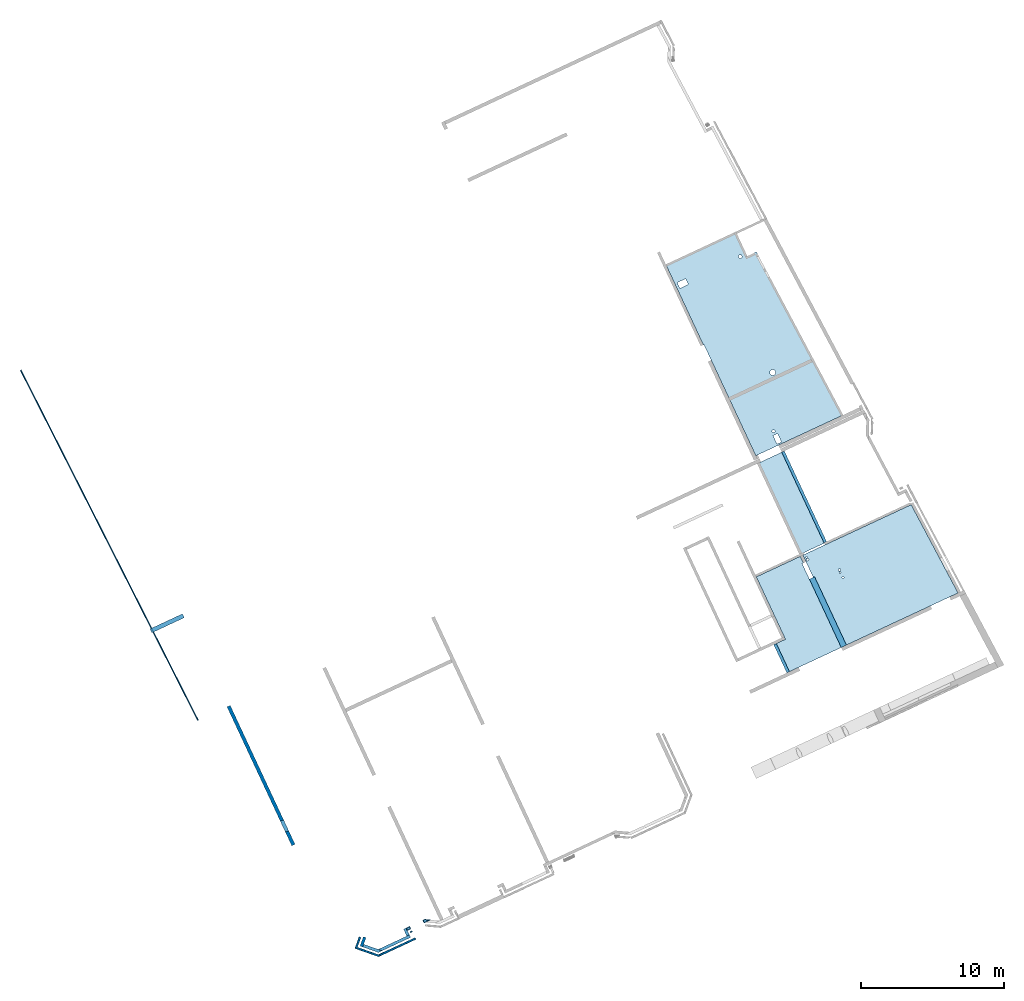
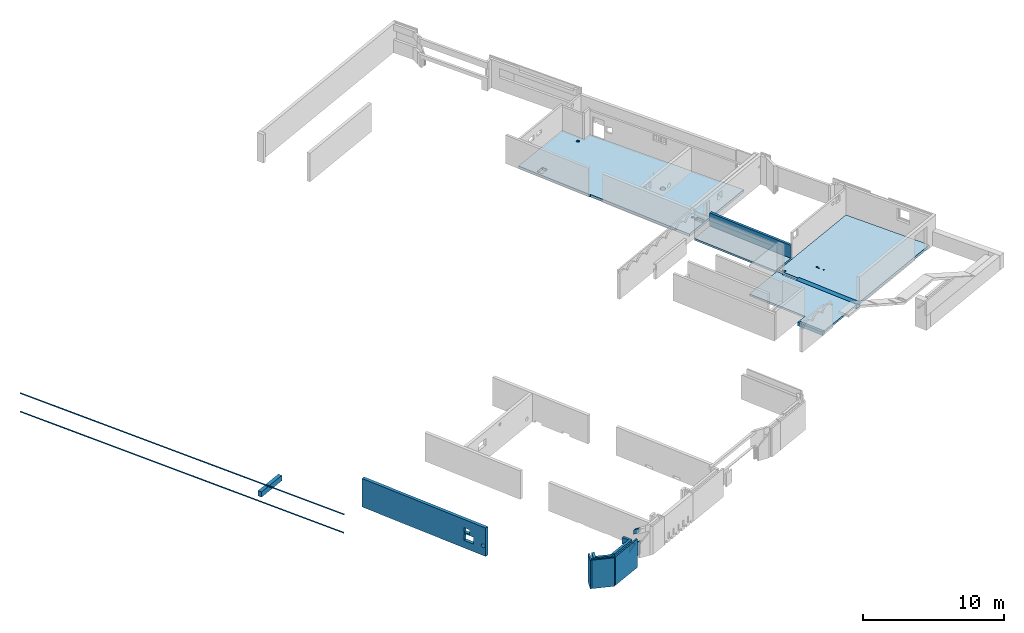
# One storey, part 1 of 13: 10 walls, 6 beams, 4 slabs, 18 openings.
"""IFC2X3 building model written with IfcOpenShell, lengths in metres."""

import ifcopenshell
import ifcopenshell.guid

model = None  # the IFC model being written
_history = None  # IfcOwnerHistory: only IFC2X3 demands one
_inside = {}  # id of a spatial element -> (the spatial element, [elements in it])
_under = {}  # id of a project, library or spatial element -> (it, [spatial elements below it])
_declared = {}  # id of a project -> (the project, [libraries it declares])
_typed = {}  # id of a type object -> (the type object, [elements of that type])
_made_of = {}  # id of a material, layer set ... -> (it, [elements and type objects made of it])


def new_model(schema):
    """Start an empty IFC model of exactly this schema.

    Asked for "IFC4X3", IfcOpenShell would pick the latest addendum, in which some entities
    have other attributes; the version numbers below select the first issue.
    IFC2X3 requires an IfcOwnerHistory on every rooted entity: one is made here for all.
    """
    global model, _history
    if schema == "IFC4X3":
        model = ifcopenshell.file(schema_version=(4, 3, 0, 0))
    else:
        model = ifcopenshell.file(schema=schema)
    _inside.clear()
    _under.clear()
    _declared.clear()
    _typed.clear()
    _made_of.clear()
    _history = None
    if model.schema == "IFC2X3":
        org = make("IfcOrganization", Name="unknown")
        user = make(
            "IfcPersonAndOrganization",
            ThePerson=make("IfcPerson", FamilyName="unknown"),
            TheOrganization=org,
        )
        app = make(
            "IfcApplication",
            ApplicationDeveloper=org,
            Version="unknown",
            ApplicationFullName="unknown",
            ApplicationIdentifier="unknown",
        )
        _history = make(
            "IfcOwnerHistory",
            OwningUser=user,
            OwningApplication=app,
            ChangeAction="ADDED",
            CreationDate=0,
        )
    return model


def make(cls, **values):
    """One entity of the class cls with the attributes given. An attribute that is None is left unset."""
    return model.create_entity(
        cls, **{name: value for name, value in values.items() if value is not None}
    )


def entity(cls, *values):
    """Any entity or typed value of the class cls, its attributes in the order of the schema. None: left unset."""
    e = model.create_entity(cls)
    for i, value in enumerate(values):
        if value is not None:
            e[i] = value
    return e


def rooted(cls, **values):
    """An entity with a GlobalId (a new one), such as an element, a storey or a relation."""
    return make(cls, GlobalId=ifcopenshell.guid.new(), OwnerHistory=_history, **values)


def si_unit(unit_type, name, prefix=None):
    """IfcSIUnit, for example si_unit("LENGTHUNIT", "METRE", prefix="MILLI")."""
    return make("IfcSIUnit", UnitType=unit_type, Prefix=prefix, Name=name)


def converted_unit(unit_type, name, factor, base, dimensions=None, offset=None):
    """IfcConversionBasedUnit, such as the inch: factor (a typed value) times the base unit."""
    return make(
        "IfcConversionBasedUnit"
        if offset is None
        else "IfcConversionBasedUnitWithOffset",
        ConversionOffset=offset,
        Dimensions=None
        if dimensions is None
        else entity("IfcDimensionalExponents", *dimensions),
        UnitType=unit_type,
        Name=name,
        ConversionFactor=make(
            "IfcMeasureWithUnit", ValueComponent=factor, UnitComponent=base
        ),
    )


def derived_unit(unit_type, elements):
    """IfcDerivedUnit: a product of units, each with its exponent."""
    return make(
        "IfcDerivedUnit",
        Elements=[
            make("IfcDerivedUnitElement", Unit=unit, Exponent=power)
            for unit, power in elements
        ],
        UnitType=unit_type,
    )


def assignment(units):
    """IfcUnitAssignment: the units of a project."""
    return None if units is None else make("IfcUnitAssignment", Units=units)


def point(xyz):
    """IfcCartesianPoint."""
    return None if xyz is None else make("IfcCartesianPoint", Coordinates=xyz)


def direction(xyz):
    """IfcDirection."""
    return None if xyz is None else make("IfcDirection", DirectionRatios=xyz)


def frame(location, z_axis=None, x_axis=None):
    """IfcAxis2Placement3D, a coordinate frame: its origin and axes. An axis left out is left unset."""
    return make(
        "IfcAxis2Placement3D",
        Location=point(location),
        Axis=direction(z_axis),
        RefDirection=direction(x_axis),
    )


def frame_2d(location, x_axis=None):
    """IfcAxis2Placement2D, a coordinate frame in the plane: its origin and x axis."""
    return make(
        "IfcAxis2Placement2D", Location=point(location), RefDirection=direction(x_axis)
    )


def origin():
    """The frame at (0, 0, 0) with its axes left unset."""
    return frame((0.0, 0.0, 0.0))


def origin_2d_with_axis():
    """The frame at (0, 0) in the plane with the x axis (1, 0) written out."""
    return frame_2d((0.0, 0.0), x_axis=(1.0, 0.0))


def place(relative_to, where):
    """IfcLocalPlacement: puts the frame where relative to a parent placement (None: the world)."""
    return make(
        "IfcLocalPlacement", PlacementRelTo=relative_to, RelativePlacement=where
    )


def context(
    kind, dimensions, precision=None, world=None, true_north=None, identifier=None
):
    """IfcGeometricRepresentationContext, for example the 3D "Model" context."""
    return make(
        "IfcGeometricRepresentationContext",
        ContextIdentifier=identifier,
        ContextType=kind,
        CoordinateSpaceDimension=dimensions,
        Precision=precision,
        WorldCoordinateSystem=world,
        TrueNorth=true_north,
    )


def subcontext(parent, identifier, kind, view, scale=None):
    """IfcGeometricRepresentationSubContext, for example "Body" below "Model"."""
    return make(
        "IfcGeometricRepresentationSubContext",
        ContextIdentifier=identifier,
        ContextType=kind,
        ParentContext=parent,
        TargetScale=scale,
        TargetView=view,
    )


def project(units=None, contexts=None):
    """IfcProject with its units and contexts."""
    return rooted(
        "IfcProject",
        Name="project",
        RepresentationContexts=contexts,
        UnitsInContext=assignment(units),
    )


def spatial(cls, under=None, at=None, **own):
    """A site, building, storey or space (cls), placed at a placement, below another one or the project."""
    s = rooted(cls, ObjectPlacement=at, **own)
    if under is not None:
        _under.setdefault(under.id(), (under, []))[1].append(s)
    return s


def polyline(points):
    """IfcPolyline through the points."""
    return make("IfcPolyline", Points=[point(p) for p in points])


def profile(cls, at=None, kind="AREA", **sizes):
    """A parametric profile (cls). Its sizes go by their IFC names, for example OverallWidth=200.0."""
    return make(cls, ProfileType=kind, Position=at, **sizes)


def rectangle(**sizes):
    """IfcRectangleProfileDef."""
    return profile("IfcRectangleProfileDef", **sizes)


def circle(**sizes):
    """IfcCircleProfileDef."""
    return profile("IfcCircleProfileDef", **sizes)


def hollow_circle(**sizes):
    """IfcCircleHollowProfileDef."""
    return profile("IfcCircleHollowProfileDef", **sizes)


def outline(outer, holes=None, kind="AREA"):
    """IfcArbitraryClosedProfileDef: a profile drawn as a closed curve; with holes, ...WithVoids."""
    if holes is None:
        return make("IfcArbitraryClosedProfileDef", ProfileType=kind, OuterCurve=outer)
    return make(
        "IfcArbitraryProfileDefWithVoids",
        ProfileType=kind,
        OuterCurve=outer,
        InnerCurves=holes,
    )


def extrude(swept, where, along, depth):
    """IfcExtrudedAreaSolid: the profile swept, set in the frame where, extruded along a direction by depth."""
    return make(
        "IfcExtrudedAreaSolid",
        SweptArea=swept,
        Position=where,
        ExtrudedDirection=direction(along),
        Depth=depth,
    )


def clip(a, b, op="DIFFERENCE"):
    """IfcBooleanClippingResult: the solid a cut by the half space b."""
    return make(
        "IfcBooleanClippingResult", Operator=op, FirstOperand=a, SecondOperand=b
    )


def halfspace(plane, agree):
    """IfcHalfSpaceSolid: all space on one side of the plane z = 0 of the frame plane."""
    return make(
        "IfcHalfSpaceSolid",
        BaseSurface=make("IfcPlane", Position=plane),
        AgreementFlag=agree,
    )


def shape(context_of_items, identifier, shape_type, items):
    """IfcShapeRepresentation: the items that make up one representation, for example the "Body"."""
    return make(
        "IfcShapeRepresentation",
        ContextOfItems=context_of_items,
        RepresentationIdentifier=identifier,
        RepresentationType=shape_type,
        Items=items,
    )


def material(Name=None, Category=None):
    """IfcMaterial."""
    return make("IfcMaterial", Name=Name, Category=Category)


def layer(
    of_material, thickness, ventilated=None, Name=None, Category=None, Priority=None
):
    """IfcMaterialLayer: one layer of a wall or slab, of a material (None: an air gap)."""
    return make(
        "IfcMaterialLayer",
        Material=of_material,
        LayerThickness=thickness,
        IsVentilated=ventilated,
        Name=Name,
        Category=Category,
        Priority=Priority,
    )


def layer_set(layers, Name=None):
    """IfcMaterialLayerSet."""
    return make("IfcMaterialLayerSet", MaterialLayers=layers, LayerSetName=Name)


def layer_usage(for_layer_set, set_direction, sense, offset, extent=None):
    """IfcMaterialLayerSetUsage: how a layer set lies in its element."""
    return make(
        "IfcMaterialLayerSetUsage",
        ForLayerSet=for_layer_set,
        LayerSetDirection=set_direction,
        DirectionSense=sense,
        OffsetFromReferenceLine=offset,
        ReferenceExtent=extent,
    )


def made_of(thing, what):
    """Note that an element or type object is made of a material, layer set ...; save() writes the relation."""
    if what is not None:
        _made_of.setdefault(what.id(), (what, []))[1].append(thing)
    return thing


def type_object(cls, material=None, **own):
    """A type object (cls), such as IfcWallType, which elements share."""
    return made_of(rooted(cls, **own), material)


def element(
    cls,
    number,
    at=None,
    inside=None,
    cuts=None,
    type_object=None,
    material=None,
    context=None,
    identifier="Body",
    shape_type=None,
    held_by="IfcProductDefinitionShape",
    body=None,
    shapes=None,
    **own,
):
    """One element of the class cls, such as IfcWall. Its Tag is "e" and its number.

    at: its placement. inside: the storey or other place that contains it. cuts: it is an
    opening in that element (IfcRelVoidsElement). A single representation is given by context,
    identifier, shape_type and body (its items); several are given by shapes. held_by: the class
    of the entity that holds the representations. save() writes the other relations.
    """
    e = rooted(cls, Tag="e%d" % number, ObjectPlacement=at, **own)
    if body is not None:
        shapes = [shape(context, identifier, shape_type, body)]
    if shapes is not None:
        e.Representation = make(held_by, Representations=shapes)
    if inside is not None:
        _inside.setdefault(inside.id(), (inside, []))[1].append(e)
    if cuts is not None:
        rooted(
            "IfcRelVoidsElement", RelatingBuildingElement=cuts, RelatedOpeningElement=e
        )
    if type_object is not None:
        _typed.setdefault(type_object.id(), (type_object, []))[1].append(e)
    return made_of(e, material)


def aggregate(whole, parts):
    """IfcRelAggregates: a whole, such as a stair, and the parts it consists of."""
    return rooted("IfcRelAggregates", RelatingObject=whole, RelatedObjects=parts)


def save(model, path):
    """Write the relations noted so far, then the file.

    IfcRelAggregates (storeys below a building ...), IfcRelContainedInSpatialStructure (elements
    in a storey), IfcRelDefinesByType, IfcRelAssociatesMaterial and IfcRelDeclares: one each for
    every whole, place, type object, material and project.
    """
    for whole, parts in _under.values():
        aggregate(whole, parts)
    for where, things in _inside.values():
        rooted(
            "IfcRelContainedInSpatialStructure",
            RelatedElements=things,
            RelatingStructure=where,
        )
    for kind, things in _typed.values():
        rooted("IfcRelDefinesByType", RelatedObjects=things, RelatingType=kind)
    for what, things in _made_of.values():
        rooted("IfcRelAssociatesMaterial", RelatedObjects=things, RelatingMaterial=what)
    for by, libraries in _declared.values():
        rooted("IfcRelDeclares", RelatingContext=by, RelatedDefinitions=libraries)
    model.write(path)


model = new_model("IFC2X3")

# Units and contexts
model_context = context("Model", 3, precision=1e-05, world=origin(), true_north=direction((6.12303176911189e-17, 1.0)))
body_context = subcontext(model_context, "Body", "Model", "MODEL_VIEW")
ifc_project = project(units=[si_unit("LENGTHUNIT", "METRE"), si_unit("AREAUNIT", "SQUARE_METRE"), si_unit("VOLUMEUNIT", "CUBIC_METRE"), converted_unit("PLANEANGLEUNIT", "DEGREE", entity("IfcRatioMeasure", 0.0174532925199433), si_unit("PLANEANGLEUNIT", "RADIAN"), dimensions=[0, 0, 0, 0, 0, 0, 0]), si_unit("MASSUNIT", "GRAM", prefix="KILO"), derived_unit("MASSDENSITYUNIT", [(si_unit("MASSUNIT", "GRAM", prefix="KILO"), 1), (si_unit("LENGTHUNIT", "METRE"), -3)]), si_unit("TIMEUNIT", "SECOND"), si_unit("FREQUENCYUNIT", "HERTZ"), si_unit("THERMODYNAMICTEMPERATUREUNIT", "DEGREE_CELSIUS"), derived_unit("THERMALTRANSMITTANCEUNIT", [(si_unit("MASSUNIT", "GRAM", prefix="KILO"), 1), (si_unit("THERMODYNAMICTEMPERATUREUNIT", "KELVIN"), -1), (si_unit("TIMEUNIT", "SECOND"), -3)]), derived_unit("VOLUMETRICFLOWRATEUNIT", [(si_unit("LENGTHUNIT", "METRE"), 3), (si_unit("TIMEUNIT", "SECOND"), -1)]), si_unit("ELECTRICCURRENTUNIT", "AMPERE"), si_unit("ELECTRICVOLTAGEUNIT", "VOLT"), si_unit("POWERUNIT", "WATT"), si_unit("FORCEUNIT", "NEWTON", prefix="KILO"), si_unit("ILLUMINANCEUNIT", "LUX"), si_unit("LUMINOUSFLUXUNIT", "LUMEN"), si_unit("LUMINOUSINTENSITYUNIT", "CANDELA"), derived_unit("USERDEFINED", [(si_unit("MASSUNIT", "GRAM", prefix="KILO"), -1), (si_unit("LENGTHUNIT", "METRE"), -2), (si_unit("TIMEUNIT", "SECOND"), 3), (si_unit("LUMINOUSFLUXUNIT", "LUMEN"), 1)]), derived_unit("LINEARVELOCITYUNIT", [(si_unit("LENGTHUNIT", "METRE"), 1), (si_unit("TIMEUNIT", "SECOND"), -1)]), si_unit("PRESSUREUNIT", "PASCAL"), derived_unit("USERDEFINED", [(si_unit("LENGTHUNIT", "METRE"), -2), (si_unit("MASSUNIT", "GRAM", prefix="KILO"), 1), (si_unit("TIMEUNIT", "SECOND"), -2)])], contexts=[model_context])

# Site, building, storey
site_placement = place(None, frame((5.36960000000003, 43.3158000000006, 0.0), z_axis=(0.0, 0.0, 1.0), x_axis=(-0.422618261740703, 0.906307787036648, 0.0)))
site = spatial("IfcSite", under=ifc_project, at=site_placement, CompositionType="ELEMENT")
building_placement = place(site_placement, origin())
building = spatial("IfcBuilding", under=site, at=building_placement, CompositionType="ELEMENT")
storey_placement = place(building_placement, frame((0.0, 0.0, 2.56)))
storey = spatial("IfcBuildingStorey", under=building, at=storey_placement, CompositionType="ELEMENT", Elevation=2.56)

# Beams
ifc_material_1 = material(Name="Acier structurel - S235")
beam_type_1 = type_object("IfcBeamType", Name="CHM_10_:01_Rond Creux 101.6x5", PredefinedType="BEAM", material=ifc_material_1)
beam_1_placement = place(storey_placement, frame((47.7991430909381, 53.683780797535, 0.690825037722072), z_axis=(-1.66798992952093e-06, -5.39854392808255e-08, 1.0), x_axis=(-0.999476646181147, -0.0323486280342907, -1.6688633355184e-06)))
element("IfcBeam", 1, at=beam_1_placement, inside=storey, type_object=beam_type_1, material=ifc_material_1, Name="10_:01_Rond Creux 101.6x5", ObjectType="CHM_10_:01_Rond Creux 101.6x5", context=body_context, shape_type="SweptSolid", body=[
    extrude(hollow_circle(Radius=0.0508000000000008, WallThickness=0.0050000000000008, at=origin_2d_with_axis()), frame((-0.00220000000009409, 0.0, -0.0508000000000042), z_axis=(1.0, 0.0, 0.0), x_axis=(0.0, 1.0, 0.0)), (0.0, 0.0, 1.0), 27.4882),
])
beam_2_placement = place(storey_placement, frame((47.8006608482374, 53.6837846191832, -0.909199999999946), z_axis=(0.0, 0.0, 1.0), x_axis=(-0.999476646182541, -0.0323486280342909, 0.0)))
element("IfcBeam", 2, at=beam_2_placement, inside=storey, type_object=beam_type_1, material=ifc_material_1, Name="10_:01_Rond Creux 101.6x5", ObjectType="CHM_10_:01_Rond Creux 101.6x5", context=body_context, shape_type="SweptSolid", body=[
    extrude(hollow_circle(Radius=0.0508000000000008, WallThickness=0.0050000000000008, at=frame_2d((0.0, -2.70716782324598e-16), x_axis=(1.0, 0.0))), frame((-0.000687526736847471, 0.0, -0.0508000000000039), z_axis=(1.0, 0.0, 0.0), x_axis=(0.0, 1.0, 0.0)), (0.0, 0.0, 1.0), 27.4653),
])
ifc_material_2 = material(Name="C25/30 XC1")
beam_type_2 = type_object("IfcBeamType", Name="SP_20_:15_Poutre 20x128h", PredefinedType="BEAM")
beam_3_placement = place(storey_placement, frame((13.0006608482374, 7.73252584902486, -0.159999999999997)))
element("IfcBeam", 3, at=beam_3_placement, inside=storey, type_object=beam_type_2, material=ifc_material_2, Name="SP_20_:15_Poutre 20x128h", ObjectType="SP_20_:15_Poutre 20x128h", context=body_context, shape_type="SweptSolid", body=[
    extrude(rectangle(XDim=1.12, YDim=0.2, at=frame_2d((5.55111512312578e-16, 5.84740589282262e-14), x_axis=(1.0, 0.0))), frame((0.0799999999999998, 0.0, 0.719999999999998), z_axis=(1.0, 0.0, 0.0), x_axis=(0.0, 0.0, -1.0)), (0.0, 0.0, 1.0), 6.99500115363823),
])
ifc_material_3 = material(Name="C40/50 XC1")
beam_type_3 = type_object("IfcBeamType", Name="SP_20_:31_Poutre 40x40h", PredefinedType="BEAM")
beam_4_placement = place(storey_placement, frame((5.8006608482374, 9.63252584903126, 0.0)))
element("IfcBeam", 4, at=beam_4_placement, inside=storey, type_object=beam_type_3, material=ifc_material_3, Name="SP_20_:31_Poutre 40x40h", ObjectType="SP_20_:31_Poutre 40x40h", context=body_context, shape_type="SweptSolid", body=[
    extrude(rectangle(XDim=0.4, YDim=0.4, at=frame_2d((0.0, 4.81659157003378e-12), x_axis=(1.0, 0.0))), frame((0.12499999999982, 0.0, -0.200000000000002), z_axis=(1.0, 0.0, 0.0), x_axis=(0.0, 0.0, -1.0)), (0.0, 0.0, 1.0), 5.27500050894108),
])
beam_type_4 = type_object("IfcBeamType", Name="SP_20_:05_Poutre 20 x 31ht", PredefinedType="BEAM")
beam_5_placement = place(storey_placement, frame((8.20066084823747, 13.9325037603591, 0.0), z_axis=(0.0, 0.0, 1.0), x_axis=(-1.0, 0.0, 0.0)))
element("IfcBeam", 5, at=beam_5_placement, inside=storey, type_object=beam_type_4, material=ifc_material_2, Name="SP_20_:05_Poutre 20 x 31ht", ObjectType="SP_20_:05_Poutre 20 x 31ht", context=body_context, shape_type="SweptSolid", body=[
    extrude(rectangle(XDim=0.31, YDim=0.199999999999998, at=frame_2d((0.0, 2.38212227721135e-14), x_axis=(1.0, 0.0))), frame((0.100001063957546, 0.0, -0.155000000000002), z_axis=(1.0, 0.0, 0.0), x_axis=(0.0, 0.0, -1.0)), (0.0, 0.0, 1.0), 2.175),
])
ifc_material_4 = material(Name="C30/37 XS1")
beam_type_5 = type_object("IfcBeamType", Name="SP_20_:26_Poutre 30x46h", PredefinedType="BEAM")
beam_6_placement = place(storey_placement, frame((27.4006192535275, 53.1373971249629, 0.0), z_axis=(0.0, 0.0, 1.0), x_axis=(0.0, -1.0, 0.0)))
element("IfcBeam", 6, at=beam_6_placement, inside=storey, type_object=beam_type_5, material=ifc_material_4, Name="SP_20_:26_Poutre 30x46h", ObjectType="SP_20_:26_Poutre 30x46h", context=body_context, shape_type="SweptSolid", body=[
    extrude(rectangle(XDim=0.46, YDim=0.300000000000005, at=frame_2d((2.63677968348475e-16, 2.16493489801906e-15), x_axis=(1.0, 0.0))), frame((0.0, 0.0, -0.230000000000001), z_axis=(1.0, 0.0, 0.0), x_axis=(0.0, 0.0, -1.0)), (0.0, 0.0, 1.0), 2.50770000000001),
])

# Slab, openings
ifc_layer_1 = layer(ifc_material_2, 0.22)
ifc_layer_set_1 = layer_set([ifc_layer_1], Name="Sol:SP_40_06_Dalle BET22")
ifc_layer_usage_1 = layer_usage(ifc_layer_set_1, "AXIS3", "POSITIVE", 0.0)
slab_type_1 = type_object("IfcSlabType", Name="Sol:SP_40_06_Dalle BET22", PredefinedType="FLOOR", material=ifc_layer_set_1)
slab_1_placement = place(storey_placement, frame((20.6156620018758, 2.83449320546499, -0.160000000000001)))
slab_1 = element("IfcSlab", 7, at=slab_1_placement, inside=storey, type_object=slab_type_1, material=ifc_layer_usage_1, Name="Sol:SP_40_06_Dalle BET22", ObjectType="Sol:SP_40_06_Dalle BET22", PredefinedType="FLOOR", context=body_context, shape_type="SweptSolid", body=[
    extrude(outline(polyline([(-7.40276950259555, -2.01885991005166), (-5.51222725007326, -2.01885991005165), (-5.51222725007325, -2.72496830778786), (7.40276950259559, -3.39901632177972), (7.40276950259553, 3.34901632177979), (-1.18222934376573, 3.34901632177972), (-1.18222934376573, 3.39901632177979), (-7.4027695025956, 3.39901632177972), (-7.40276950259555, -2.01885991005166)])), frame((7.40276950259559, 3.39901632177972, 0.220000000000001), z_axis=(0.0, 0.0, -1.0), x_axis=(-1.0, 0.0, 0.0)), (0.0, 0.0, 1.0), 0.22),
])
opening_1_placement = place(slab_1_placement, origin())
element("IfcOpeningElement", 8, at=opening_1_placement, cuts=slab_1, ObjectType="Opening", context=body_context, shape_type="SweptSolid", body=[
    extrude(rectangle(XDim=0.35, YDim=0.649999999999999, at=origin_2d_with_axis()), frame((0.439440943100025, 4.88117728273939, -0.0800000000000013), z_axis=(0.0, 0.0, 1.0), x_axis=(0.0, 1.0, 0.0)), (0.0, 0.0, 1.0), 0.5),
])
opening_2_placement = place(slab_1_placement, origin())
element("IfcOpeningElement", 9, at=opening_2_placement, cuts=slab_1, ObjectType="Opening", context=body_context, shape_type="SweptSolid", body=[
    extrude(circle(Radius=0.200000000000012, at=origin_2d_with_axis()), frame((4.78470411792951, 3.21118867164955, -0.0800000000000013)), (0.0, 0.0, 1.0), 0.5),
])
opening_3_placement = place(slab_1_placement, origin())
element("IfcOpeningElement", 10, at=opening_3_placement, cuts=slab_1, ObjectType="Opening", context=body_context, shape_type="SweptSolid", body=[
    extrude(circle(Radius=0.0999999999999979, at=origin_2d_with_axis()), frame((1.02944094309986, 4.89818423578489, -0.0800000000000013)), (0.0, 0.0, 1.0), 0.5),
])
opening_4_placement = place(slab_1_placement, origin())
element("IfcOpeningElement", 11, at=opening_4_placement, cuts=slab_1, ObjectType="Opening", context=body_context, shape_type="SweptSolid", body=[
    extrude(circle(Radius=0.124999999999998, at=origin_2d_with_axis()), frame((13.1000212835624, 1.84812233774764, -0.0800000000000013)), (0.0, 0.0, 1.0), 0.5),
])
opening_5_placement = place(slab_1_placement, origin())
element("IfcOpeningElement", 12, at=opening_5_placement, cuts=slab_1, ObjectType="Opening", context=body_context, shape_type="SweptSolid", body=[
    extrude(rectangle(XDim=0.444999999999999, YDim=0.649999999999999, at=origin_2d_with_axis()), frame((13.0869409430997, 6.28525567428294, -0.0800000000000013), z_axis=(0.0, 0.0, 1.0), x_axis=(-1.0, 0.0, 0.0)), (0.0, 0.0, 1.0), 0.5),
])

ifc_layer_usage_2 = layer_usage(ifc_layer_set_1, "AXIS3", "POSITIVE", 0.0)
slab_2_placement = place(storey_placement, frame((5.92566084823725, 0.806025013909039, -0.22)))
slab_2 = element("IfcSlab", 13, at=slab_2_placement, inside=storey, type_object=slab_type_1, material=ifc_layer_usage_2, Name="Sol:SP_40_06_Dalle BET22", ObjectType="Sol:SP_40_06_Dalle BET22", PredefinedType="FLOOR", context=body_context, shape_type="SweptSolid", body=[
    extrude(outline(polyline([(3.4975000000001, 4.3632504175576), (-3.49750000000017, 4.36325041755753), (-3.4975000000001, -3.99817328560245), (3.49750000000018, -4.36325041755754), (3.4975000000001, 4.3632504175576)])), frame((3.49750000000018, 4.36325041755754, 0.22), z_axis=(0.0, 0.0, -1.0), x_axis=(-1.0, 0.0, 0.0)), (0.0, 0.0, 1.0), 0.22),
])
opening_6_placement = place(storey_placement, frame((5.92566084823725, 0.806025013909039, -0.22)))
element("IfcOpeningElement", 14, at=opening_6_placement, cuts=slab_2, ObjectType="Opening", context=body_context, shape_type="SweptSolid", body=[
    extrude(circle(Radius=0.08, at=frame_2d((-3.06776047783623, 4.19505917639782), x_axis=(1.0, 0.0))), frame((3.49750000000018, 4.36325041755754, 0.22), z_axis=(0.0, 0.0, -1.0), x_axis=(-1.0, 0.0, 0.0)), (0.0, 0.0, 1.0), 0.22),
])
opening_7_placement = place(storey_placement, frame((5.92566084823725, 0.806025013909039, -0.22)))
element("IfcOpeningElement", 15, at=opening_7_placement, cuts=slab_2, ObjectType="Opening", context=body_context, shape_type="SweptSolid", body=[
    extrude(circle(Radius=0.05, at=frame_2d((-3.25420201195466, 4.19326188063582), x_axis=(1.0, 0.0))), frame((3.49750000000018, 4.36325041755754, 0.22), z_axis=(0.0, 0.0, -1.0), x_axis=(-1.0, 0.0, 0.0)), (0.0, 0.0, 1.0), 0.22),
])
opening_8_placement = place(storey_placement, frame((5.92566084823725, 0.806025013909039, -0.22)))
element("IfcOpeningElement", 16, at=opening_8_placement, cuts=slab_2, ObjectType="Opening", context=body_context, shape_type="SweptSolid", body=[
    extrude(circle(Radius=0.08, at=frame_2d((-1.46885343441837, 2.48471308064029), x_axis=(1.0, 0.0))), frame((3.49750000000018, 4.36325041755754, 0.22), z_axis=(0.0, 0.0, -1.0), x_axis=(-1.0, 0.0, 0.0)), (0.0, 0.0, 1.0), 0.22),
])
opening_9_placement = place(storey_placement, frame((5.92566084823725, 0.806025013909039, -0.22)))
element("IfcOpeningElement", 17, at=opening_9_placement, cuts=slab_2, ObjectType="Opening", context=body_context, shape_type="SweptSolid", body=[
    extrude(circle(Radius=0.05, at=frame_2d((-1.28086247834289, 2.52366248719849), x_axis=(1.0, 0.0))), frame((3.49750000000018, 4.36325041755754, 0.22), z_axis=(0.0, 0.0, -1.0), x_axis=(-1.0, 0.0, 0.0)), (0.0, 0.0, 1.0), 0.22),
])
opening_10_placement = place(storey_placement, frame((5.92566084823725, 0.806025013909039, -0.22)))
element("IfcOpeningElement", 18, at=opening_10_placement, cuts=slab_2, ObjectType="Opening", context=body_context, shape_type="SweptSolid", body=[
    extrude(circle(Radius=0.0625, at=frame_2d((-0.888853434418433, 2.48471308064029), x_axis=(1.0, 0.0))), frame((3.49750000000018, 4.36325041755754, 0.22), z_axis=(0.0, 0.0, -1.0), x_axis=(-1.0, 0.0, 0.0)), (0.0, 0.0, 1.0), 0.22),
])

# Slabs
ifc_layer_2 = layer(ifc_material_2, 0.16)
ifc_layer_set_2 = layer_set([ifc_layer_2], Name="Sol:SP_40_02_Dalle BET16")
ifc_layer_usage_3 = layer_usage(ifc_layer_set_2, "AXIS3", "POSITIVE", 0.0)
slab_type_2 = type_object("IfcSlabType", Name="Sol:SP_40_02_Dalle BET16", PredefinedType="FLOOR", material=ifc_layer_set_2)
slab_3_placement = place(storey_placement, origin())
element("IfcSlab", 19, at=slab_3_placement, inside=storey, type_object=slab_type_2, material=ifc_layer_usage_3, Name="Sol:SP_40_02_Dalle BET16", ObjectType="Sol:SP_40_02_Dalle BET16", PredefinedType="FLOOR", context=body_context, shape_type="SweptSolid", body=[
    extrude(rectangle(XDim=2.09999999999978, YDim=7.02901887675827, at=frame_2d((0.0, -2.22044604925031e-15), x_axis=(1.0, 0.0))), frame((16.561152563497, 8.68252584902456, 0.0), z_axis=(0.0, 0.0, -1.0), x_axis=(0.0, 1.0, 0.0)), (0.0, 0.0, 1.0), 0.16),
])
ifc_layer_usage_4 = layer_usage(ifc_layer_set_2, "AXIS3", "POSITIVE", 0.0)
slab_4_placement = place(storey_placement, origin())
element("IfcSlab", 20, at=slab_4_placement, inside=storey, type_object=slab_type_2, material=ifc_layer_usage_4, Name="Sol:SP_40_02_Dalle BET16", ObjectType="Sol:SP_40_02_Dalle BET16", PredefinedType="FLOOR", context=body_context, shape_type="SweptSolid", body=[
    extrude(outline(polyline([(-1.79998895566005, -3.91125159593633), (2.19998895566776, -3.91125159593633), (2.19998895566775, -1.73624946802136), (1.49998895566744, -1.73624946802136), (1.49998895566742, 3.083750531979), (-1.89998895567221, 3.083750531979), (-1.89998895567221, 2.56375053197869), (-1.7999889556665, 2.56375053197869), (-1.79998895566005, -3.91125159593633)])), frame((9.83691031625877, 11.6325148046912, 0.0), z_axis=(0.0, 0.0, -1.0), x_axis=(0.0, 1.0, 0.0)), (0.0, 0.0, 1.0), 0.16),
])

# Wall, openings
ifc_material_5 = material(Name="C30/37 XC1")
ifc_layer_3 = layer(ifc_material_5, 0.25)
ifc_layer_set_3 = layer_set([ifc_layer_3])
ifc_layer_usage_5 = layer_usage(ifc_layer_set_3, "AXIS2", "NEGATIVE", 0.125)
wall_type_1 = type_object("IfcWallType", PredefinedType="NOTDEFINED", material=ifc_layer_set_3)
wall_1_placement = place(storey_placement, frame((9.60066084823737, 50.4325026819599, 0.0)))
wall_1 = element("IfcWallStandardCase", 21, at=wall_1_placement, inside=storey, type_object=wall_type_1, material=ifc_layer_usage_5, Name="XS1", context=body_context, shape_type="Clipping", body=[
    clip(extrude(rectangle(XDim=10.7300917482538, YDim=0.249999999999995, at=frame_2d((5.36504587412689, -9.29811783123569e-16), x_axis=(-1.0, 0.0))), origin(), (0.0, 0.0, 1.0), 2.47), halfspace(frame((0.0, 0.0, -2.56)), True)),
])
opening_11_placement = place(wall_1_placement, origin())
element("IfcOpeningElement", 22, at=opening_11_placement, cuts=wall_1, Name="XS1", ObjectType="Opening", context=body_context, shape_type="SweptSolid", body=[
    extrude(rectangle(XDim=0.6, YDim=0.850000000000002, at=frame_2d((0.0, -2.77555756156289e-16), x_axis=(0.0, 1.0))), frame((1.46879603950529, -1.399, 0.95), z_axis=(0.0, 1.0, 0.0), x_axis=(-1.0, 0.0, 0.0)), (0.0, 0.0, 1.0), 3.048),
])
opening_12_placement = place(wall_1_placement, origin())
element("IfcOpeningElement", 23, at=opening_12_placement, cuts=wall_1, Name="XS1", ObjectType="Opening", context=body_context, shape_type="SweptSolid", body=[
    extrude(rectangle(XDim=0.4, YDim=0.500000000000001, at=frame_2d((-1.09634523681734e-15, 0.0), x_axis=(0.0, 1.0))), frame((1.63853886501964, -1.39900000000001, 1.56000262207879), z_axis=(0.0, 1.0, 0.0), x_axis=(-1.0, 0.0, 0.0)), (0.0, 0.0, 1.0), 3.048),
])
opening_13_placement = place(wall_1_placement, origin())
element("IfcOpeningElement", 24, at=opening_13_placement, cuts=wall_1, Name="XS1", ObjectType="Opening", context=body_context, shape_type="SweptSolid", body=[
    extrude(circle(Radius=0.1575, at=frame_2d((0.0, -5.41433564649196e-16), x_axis=(1.0, 0.0))), frame((0.233926897421917, -1.39900000000001, 0.839955350814131), z_axis=(0.0, 1.0, 0.0), x_axis=(-1.0, 0.0, 0.0)), (0.0, 0.0, 1.0), 3.048),
])

# Wall
ifc_layer_4 = layer(ifc_material_4, 0.2)
ifc_layer_set_4 = layer_set([ifc_layer_4])
ifc_layer_usage_6 = layer_usage(ifc_layer_set_4, "AXIS2", "NEGATIVE", 0.0999999999999944)
wall_type_2 = type_object("IfcWallType", PredefinedType="STANDARD", material=ifc_layer_set_4)
wall_2_placement = place(storey_placement, frame((1.64490532414601, 48.6373936461537, 0.0), z_axis=(0.0, 0.0, 1.0), x_axis=(-0.714364278427733, 0.699774019027875, 0.0)))
element("IfcWallStandardCase", 25, at=wall_2_placement, inside=storey, type_object=wall_type_2, material=ifc_layer_usage_6, context=body_context, shape_type="Clipping", body=[
    clip(extrude(rectangle(XDim=0.692692508823961, YDim=0.199999999999994, at=frame_2d((0.346346254411981, -6.93889390390723e-17), x_axis=(-1.0, 0.0))), origin(), (0.0, 0.0, 1.0), 2.47), halfspace(frame((0.0, 0.0, -2.56)), True)),
])

# Wall, opening
ifc_layer_usage_7 = layer_usage(ifc_layer_set_4, "AXIS2", "NEGATIVE", 0.0999999999999944)
wall_3_placement = place(storey_placement, frame((1.15345299802442, 48.9788238895031, 0.0), z_axis=(0.0, 0.0, 1.0), x_axis=(-0.699774018935306, -0.714364278518411, 0.0)))
wall_3 = element("IfcWallStandardCase", 26, at=wall_3_placement, inside=storey, type_object=wall_type_2, material=ifc_layer_usage_7, context=body_context, shape_type="Clipping", body=[
    clip(extrude(outline(polyline([(1.1594539093735, -0.0999999999999965), (1.3636239011675, 0.0999999999999927), (1.07693005849582, 0.0999999999999937), (0.320429983925171, 0.0999999999999932), (0.0, 0.0999999999999972), (0.0, -0.0999999999999973), (0.116259992131182, -0.0999999999999952), (1.07692962676829, -0.099999999999997), (1.1594539093735, -0.0999999999999965)])), origin(), (0.0, 0.0, 1.0), 2.47), halfspace(frame((0.0, 0.0, -2.56)), True)),
])
opening_14_placement = place(storey_placement, frame((1.15345299802442, 48.9788238895031, 0.0), z_axis=(0.0, 0.0, 1.0), x_axis=(-0.699774018935306, -0.714364278518411, 0.0)))
element("IfcOpeningElement", 27, at=opening_14_placement, cuts=wall_3, ObjectType="Opening", context=body_context, shape_type="SweptSolid", body=[
    extrude(outline(polyline([(-0.720179031812865, -0.119999999999997), (0.439274877560619, -0.119999999999996), (0.643444869354633, 0.0799999999999909), (0.357638316684543, 0.0799999999999914), (-0.720179031786948, 0.0799999999999925), (-0.720179031812865, -0.119999999999997)])), frame((0.720179031812859, 0.0200000000000041, 1.15)), (0.0, 0.0, 1.0), 0.77),
])

ifc_layer_usage_8 = layer_usage(ifc_layer_set_4, "AXIS2", "NEGATIVE", 0.0999999999999944)
wall_4_placement = place(storey_placement, frame((0.37066084824003, 48.1388922750756, 0.0), z_axis=(0.0, 0.0, 1.0), x_axis=(0.0, -1.0, 0.0)))
wall_4 = element("IfcWallStandardCase", 28, at=wall_4_placement, inside=storey, type_object=wall_type_2, material=ifc_layer_usage_8, context=body_context, shape_type="Clipping", body=[
    clip(extrude(outline(polyline([(2.40802567690438, -0.0999999999999944), (2.40802567690437, 0.0999999999999944), (2.20802567690439, 0.0999999999999944), (0.0, 0.0999999999999944), (0.204169991793995, -0.0999999999999944), (2.40802567690438, -0.0999999999999944)])), origin(), (0.0, 0.0, 1.0), 2.47), halfspace(frame((0.0, 0.0, -2.56)), True)),
])
opening_15_placement = place(storey_placement, frame((0.37066084824003, 48.1388922750756, 0.0), z_axis=(0.0, 0.0, 1.0), x_axis=(0.0, -1.0, 0.0)))
element("IfcOpeningElement", 29, at=opening_15_placement, cuts=wall_4, ObjectType="Opening", context=body_context, shape_type="SweptSolid", body=[
    extrude(outline(polyline([(-1.24147941270744, -0.119999999999993), (0.962376272402945, -0.119999999999993), (0.962376272402943, 0.0799999999999955), (0.762376272402954, 0.0799999999999955), (-1.44564940450143, 0.0799999999999955), (-1.24147941270744, -0.119999999999993)])), frame((1.44564940450143, 0.0199999999999989, 1.15)), (0.0, 0.0, 1.0), 0.77),
])

ifc_layer_usage_9 = layer_usage(ifc_layer_set_4, "AXIS2", "NEGATIVE", 0.0999999999999944)
wall_5_placement = place(storey_placement, frame((0.470660848240002, 45.8308665981712, 0.0)))
wall_5 = element("IfcWallStandardCase", 30, at=wall_5_placement, inside=storey, type_object=wall_type_2, material=ifc_layer_usage_9, context=body_context, shape_type="Clipping", body=[
    clip(extrude(rectangle(XDim=0.529999999997697, YDim=0.199999999999989, at=frame_2d((0.264999999998848, -1.76941794549634e-15), x_axis=(-1.0, 0.0))), origin(), (0.0, 0.0, 1.0), 2.47), halfspace(frame((0.0, 0.0, -2.56)), True)),
])
opening_16_placement = place(storey_placement, frame((0.470660848240002, 45.8308665981712, 0.0)))
element("IfcOpeningElement", 31, at=opening_16_placement, cuts=wall_5, ObjectType="Opening", context=body_context, shape_type="SweptSolid", body=[
    extrude(rectangle(XDim=0.529999999997697, YDim=0.199999999999989, at=frame_2d((-0.0129999999997613, 0.0199999999999998), x_axis=(1.0, 0.0))), frame((0.27799999999861, -0.0200000000000041, 1.15)), (0.0, 0.0, 1.0), 0.77),
])

# Walls
wall_6_placement = place(storey_placement, frame((0.900660848237704, 45.7308665981712, 0.0), z_axis=(0.0, 0.0, 1.0), x_axis=(0.0, -1.0, 0.0)))
element("IfcWall", 32, at=wall_6_placement, inside=storey, type_object=wall_type_2, context=body_context, shape_type="SweptSolid", body=[
    extrude(rectangle(XDim=0.199999999999989, YDim=0.269999999552957, at=frame_2d((-6.93889390390723e-17, 4.32986979603811e-15), x_axis=(1.0, 0.0))), frame((0.134999999776483, 0.0, 0.0), z_axis=(0.0, 0.0, 1.0), x_axis=(0.0, 1.0, 0.0)), (0.0, 0.0, 1.0), 1.15),
    extrude(outline(polyline([(-0.286602540254685, -0.0499999999999997), (0.113397459588388, -0.0499999999999997), (0.286602540254678, 0.0499999999999954), (-0.113397459588403, 0.0499999999999911), (-0.286602540254685, -0.0499999999999997)])), frame((1.49598796345866, 0.0, 1.92), z_axis=(0.0, 0.0, 1.0), x_axis=(-0.866025403671202, 0.500000000196131, 0.0)), (0.0, 0.0, 1.0), 0.38),
    extrude(outline(polyline([(-0.332496674884534, -0.0764969909966264), (0.0675033249585382, -0.0764969909966265), (0.182496674982605, -0.0101055493704905), (0.0824966749433831, 0.163099531363739), (-0.332496674884534, -0.0764969909966264)])), frame((1.44299398148619, 0.0, 0.0), z_axis=(0.0, 0.0, 1.0), x_axis=(-0.866025403671202, 0.500000000196131, 0.0)), (0.0, 0.0, 1.0), 1.15),
])
ifc_layer_5 = layer(ifc_material_4, 0.12)
ifc_layer_set_5 = layer_set([ifc_layer_5])
ifc_layer_usage_10 = layer_usage(ifc_layer_set_5, "AXIS2", "NEGATIVE", 0.06)
wall_type_3 = type_object("IfcWallType", PredefinedType="STANDARD", material=ifc_layer_set_5)
wall_7_placement = place(storey_placement, frame((1.78325033238616, 48.9358264822271, 0.0), z_axis=(0.0, 0.0, 1.0), x_axis=(-0.714364278608375, 0.699774018843466, 0.0)))
element("IfcWallStandardCase", 33, at=wall_7_placement, inside=storey, type_object=wall_type_3, material=ifc_layer_usage_10, context=body_context, shape_type="Clipping", body=[
    clip(extrude(rectangle(XDim=0.849993186913195, YDim=0.119999999999998, at=frame_2d((0.424996593456598, -3.71230823859037e-16), x_axis=(-1.0, 0.0))), origin(), (0.0, 0.0, 1.0), 2.47), halfspace(frame((0.0, 0.0, -2.56)), True)),
])
ifc_layer_usage_11 = layer_usage(ifc_layer_set_5, "AXIS2", "NEGATIVE", 0.06)
wall_8_placement = place(storey_placement, frame((1.17692097818883, 49.445781332784, 0.0), z_axis=(0.0, 0.0, 1.0), x_axis=(-0.69977401898039, -0.714364278474248, 0.0)))
element("IfcWallStandardCase", 34, at=wall_8_placement, inside=storey, type_object=wall_type_3, material=ifc_layer_usage_11, context=body_context, shape_type="Clipping", body=[
    clip(extrude(outline(polyline([(1.61966326628419, -0.0600000000000019), (1.74216526134513, 0.0600000000000004), (0.0, 0.0600000000000012), (0.0, -0.0600000000000038), (1.61966326628419, -0.0600000000000019)])), origin(), (0.0, 0.0, 1.0), 2.47), halfspace(frame((0.0, 0.0, -2.56)), True)),
])
ifc_layer_usage_12 = layer_usage(ifc_layer_set_5, "AXIS2", "NEGATIVE", 0.06)
wall_9_placement = place(storey_placement, frame((0.0606608482377805, 48.2817562568024, 0.0), z_axis=(0.0, 0.0, 1.0), x_axis=(0.0, -1.0, 0.0)))
element("IfcWallStandardCase", 35, at=wall_9_placement, inside=storey, type_object=wall_type_3, material=ifc_layer_usage_12, context=body_context, shape_type="Clipping", body=[
    clip(extrude(outline(polyline([(2.82088965818415, -0.06), (2.82088965818415, 0.06), (2.70088965818415, 0.06), (0.0, 0.06), (0.122501995060944, -0.06), (2.82088965818415, -0.06)])), origin(), (0.0, 0.0, 1.0), 2.47), halfspace(frame((0.0, 0.0, -2.56)), True)),
])

# Wall, openings
ifc_layer_usage_13 = layer_usage(ifc_layer_set_5, "AXIS2", "NEGATIVE", 0.06)
wall_10_placement = place(storey_placement, frame((0.120660848237754, 45.5208665986183, 0.0)))
wall_10 = element("IfcWallStandardCase", 36, at=wall_10_placement, inside=storey, type_object=wall_type_3, material=ifc_layer_usage_13, context=body_context, shape_type="Clipping", body=[
    clip(clip(extrude(rectangle(XDim=0.530091368591163, YDim=0.120000000000007, at=frame_2d((0.265045684295581, -1.76941794549634e-15), x_axis=(-1.0, 0.0))), origin(), (0.0, 0.0, 1.0), 2.01641552331399), halfspace(frame((0.470091368591163, 0.0, 1.14999999999935), z_axis=(-0.882212584485227, 0.0, -0.470851309625339), x_axis=(0.0, -1.0, 0.0)), False)), halfspace(frame((0.0, 0.0, -2.56)), True)),
])
opening_17_placement = place(wall_10_placement, origin())
element("IfcOpeningElement", 37, at=opening_17_placement, cuts=wall_10, ObjectType="Opening", context=body_context, shape_type="SweptSolid", body=[
    extrude(rectangle(XDim=2.56, YDim=0.12, at=frame_2d((0.0, 0.0), x_axis=(0.0, 1.0))), frame((0.470091368591163, -1.08, -0.129999999999999), z_axis=(0.0, 1.0, 0.0), x_axis=(-1.0, 0.0, 0.0)), (0.0, 0.0, 1.0), 1.02),
])
opening_18_placement = place(wall_10_placement, origin())
element("IfcOpeningElement", 38, at=opening_18_placement, cuts=wall_10, ObjectType="Opening", context=body_context, shape_type="SweptSolid", body=[
    extrude(outline(polyline([(-0.384702931568386, -0.0176710608344761), (0.741111859119914, -0.0176710608344754), (-0.356408927551529, 0.0353421216689516), (-0.384702931568386, -0.0176710608344761)])), frame((0.273363857196103, 0.059999999999995, 1.48106932538095), z_axis=(0.0, -1.0, 0.0), x_axis=(-0.470851309625339, 0.0, 0.882212584485227)), (0.0, 0.0, 1.0), 0.12),
])

save(model, "model.ifc")
